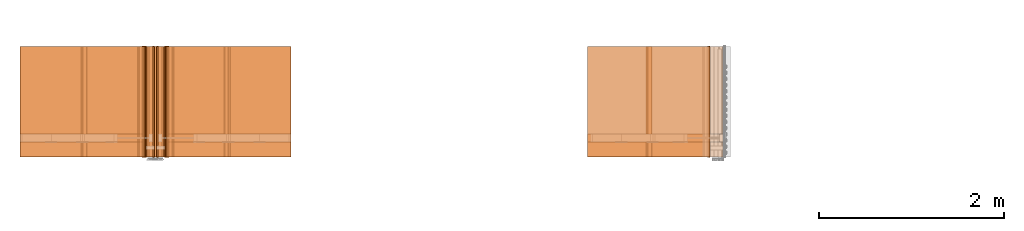
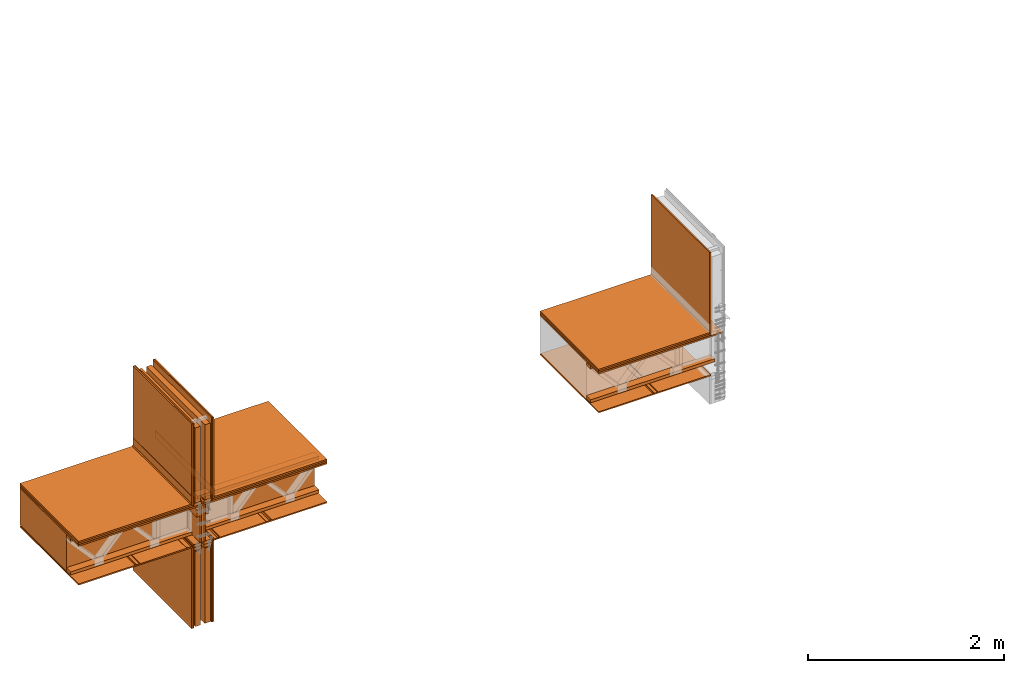
# One storey, part 1 of 22: 53 proxies.
"""IFC2X3 building model written with IfcOpenShell, lengths in feet."""

from ifc_helpers import new_model, entity, si_unit, converted_unit, frame, frame_2d, origin_with_axes, place, context, subcontext, project, spatial, polyline, rectangle, outline, extrude, element, save


model = new_model("IFC2X3")

# Units and contexts
model_context = context("Model", 3, precision=1e-05)
plan_context = context("Plan", 2, precision=1e-05, world=frame_2d((0.0, 0.0, 0.0), x_axis=(1.0, 0.0, 0.0)))
body_context_1 = subcontext(model_context, "Body", "Model", "MODEL_VIEW")
body_context_2 = subcontext(model_context, "Body", "Model", "MODEL_VIEW")
ifc_project = project(units=[converted_unit("VOLUMEUNIT", "cubic foot", entity("IfcReal", 0.0283168467116885), si_unit("VOLUMEUNIT", "CUBIC_METRE"), dimensions=[3, 0, 0, 0, 0, 0, 0]), converted_unit("AREAUNIT", "square foot", entity("IfcReal", 0.09290304), si_unit("AREAUNIT", "SQUARE_METRE"), dimensions=[2, 0, 0, 0, 0, 0, 0]), converted_unit("LENGTHUNIT", "foot", entity("IfcReal", 0.3048), si_unit("LENGTHUNIT", "METRE"), dimensions=[1, 0, 0, 0, 0, 0, 0])], contexts=[model_context, plan_context])

# Site, building, storey
site_placement = place(None, origin_with_axes())
site = spatial("IfcSite", under=ifc_project, at=site_placement, CompositionType="ELEMENT")
building_placement = place(site_placement, origin_with_axes())
building = spatial("IfcBuilding", under=site, at=building_placement, Name="Building", CompositionType="ELEMENT")
storey_placement = place(building_placement, origin_with_axes())
storey = spatial("IfcBuildingStorey", under=building, at=storey_placement, Name="Storey", CompositionType="ELEMENT")

# Proxies
proxy_1_placement = place(storey_placement, frame((1572.20384893142, 1.89104789667555, -60.1425383660424), z_axis=(0.0, 0.0, 1.0), x_axis=(1.0, 0.0, 0.0)))
element("IfcBuildingElementProxy", 1, at=proxy_1_placement, inside=storey, Name="Generic Models 841:Generic Models 1:245", context=body_context_1, shape_type="SweptSolid", body=[
    extrude(rectangle(XDim=9.6102735797045, YDim=3.92583333372057, at=frame_2d((0.0, 0.0, 0.0))), frame((3.63890071866393, 1.96291666644139, 0.0), z_axis=(0.0, 0.0, -1.0), x_axis=(-1.0, 0.0, 0.0)), (0.0, 0.0, -1.0), 0.0625000001175565),
])
proxy_2_placement = place(storey_placement, frame((1575.41560375784, 1.89104789667555, -65.0482227796019), z_axis=(0.0, 0.0, 1.0), x_axis=(-1.62920684942947e-07, 1.0, 0.0)))
element("IfcBuildingElementProxy", 2, at=proxy_2_placement, inside=storey, Name="Generic Models 845:Generic Models 1", context=body_context_1, shape_type="SweptSolid", body=[
    extrude(rectangle(XDim=3.92583333372057, YDim=0.0520833335148361, at=frame_2d((0.0, 0.0, 0.0))), frame((1.96291666644139, -0.0260416674977682, 0.0), z_axis=(0.0, 0.0, -1.0), x_axis=(-1.0, 0.0, 0.0)), (0.0, 0.0, -1.0), 3.31192968589252),
])
proxy_3_placement = place(storey_placement, frame((1572.20384893142, 1.89104789667555, -61.7362946037232), z_axis=(0.0, 0.0, 1.0), x_axis=(1.0, 0.0, 0.0)))
element("IfcBuildingElementProxy", 3, at=proxy_3_placement, inside=storey, Name="Generic Models 847:Generic Models 1:245", context=body_context_1, shape_type="SweptSolid", body=[
    extrude(rectangle(XDim=4.43001041812591, YDim=3.92583333372057, at=frame_2d((0.0, 0.0, 0.0))), frame((1.04876914675154, 1.96291666644139, 0.0), z_axis=(0.0, 0.0, -1.0), x_axis=(-0.999999940395355, 0.0, 0.0)), (0.0, 0.0, -1.0), 0.0520833335148361),
])
proxy_4_placement = place(storey_placement, frame((1572.20384893142, 1.89104789667555, -60.080036403626), z_axis=(0.0, 0.0, 1.0), x_axis=(1.0, 0.0, 0.0)))
element("IfcBuildingElementProxy", 4, at=proxy_4_placement, inside=storey, Name="Generic Models 849:Generic Models 1", context=body_context_1, shape_type="SweptSolid", body=[
    extrude(rectangle(XDim=4.43001041812591, YDim=3.92583333372057, at=frame_2d((0.0, 0.0, 0.0))), frame((1.04876914675154, 1.96291666644139, 0.0104166665407792), z_axis=(0.0, 0.0, -1.0), x_axis=(0.999999940395355, 0.0, 0.0)), (0.0, 0.0, -1.0), 0.0625000001175565),
])
proxy_5_placement = place(storey_placement, frame((1572.20384893142, 1.89104789667555, -60.017540698915), z_axis=(0.0, 0.0, 1.0), x_axis=(1.0, 0.0, 0.0)))
element("IfcBuildingElementProxy", 5, at=proxy_5_placement, inside=storey, Name="Generic Models 849:Generic Models 1", context=body_context_1, shape_type="SweptSolid", body=[
    extrude(rectangle(XDim=4.37794625465003, YDim=3.92583333372057, at=frame_2d((0.0, 0.0, 0.0))), frame((1.02273709192051, 1.96291666644139, 0.0104166665407792), z_axis=(0.0, 0.0, -1.0), x_axis=(1.0, 0.0, 0.0)), (0.0, 0.0, -1.0), 0.0625000001175565),
])
proxy_6_placement = place(storey_placement, frame((1572.20384893142, 1.89104789667555, -60.080036403626), z_axis=(0.0, 0.0, 1.0), x_axis=(1.0, 0.0, 0.0)))
element("IfcBuildingElementProxy", 6, at=proxy_6_placement, inside=storey, Name="Generic Models 849:Generic Models 1:245", context=body_context_1, shape_type="SweptSolid", body=[
    extrude(rectangle(XDim=4.43001041812591, YDim=3.92583333372057, at=frame_2d((0.0, 0.0, 0.0))), frame((1.04876914675154, 1.96291666644139, 0.0), z_axis=(0.0, 0.0, -1.0), x_axis=(-0.999999940395355, 0.0, 0.0)), (0.0, 0.0, -1.0), 0.0104166664774121),
])
proxy_7_placement = place(storey_placement, frame((1575.88438099138, 1.89104789667555, -61.8925432520589), z_axis=(0.0, 0.0, 1.0), x_axis=(-1.62920684942947e-07, 1.0, 0.0)))
element("IfcBuildingElementProxy", 7, at=proxy_7_placement, inside=storey, Name="Generic Models 857:Generic Models 1", context=body_context_1, shape_type="SweptSolid", body=[
    extrude(rectangle(XDim=0.291681873054029, YDim=3.92583333372057, at=frame_2d((0.0, 0.0, 0.0))), frame((1.96291666644139, -0.145840935233071, 0.125000001544871), z_axis=(0.0, 0.0, -1.0), x_axis=(0.0, 1.0, 0.0)), (0.0, 0.0, -1.0), 0.125000000235113),
])
proxy_8_placement = place(storey_placement, frame((1575.88438099138, 1.89104789667555, -60.080036403626), z_axis=(0.0, 0.0, 1.0), x_axis=(-1.62920684942947e-07, 1.0, 0.0)))
element("IfcBuildingElementProxy", 8, at=proxy_8_placement, inside=storey, Name="Generic Models 857:Generic Models 1", context=body_context_1, shape_type="SweptSolid", body=[
    extrude(rectangle(XDim=3.92583333372057, YDim=0.291681890238286, at=frame_2d((0.0, 0.0, 0.0))), frame((1.96291666644139, -0.145840947455152, 0.0), z_axis=(0.0, 0.0, -1.0), x_axis=(-1.0, 0.0, 0.0)), (0.0, 0.0, -1.0), 0.125000000235113),
])
proxy_9_placement = place(storey_placement, frame((1575.50931915523, 1.89104789667555, -60.080036403626), z_axis=(0.0, 0.0, 1.0), x_axis=(-1.62920684942947e-07, 1.0, 0.0)))
element("IfcBuildingElementProxy", 9, at=proxy_9_placement, inside=storey, Name="Generic Models 857:Generic Models 1", context=body_context_1, shape_type="SweptSolid", body=[
    extrude(rectangle(XDim=0.291681873054029, YDim=3.92583333372057, at=frame_2d((0.0, 0.0, 0.0))), frame((1.96291666644139, -0.145840935233071, 0.0), z_axis=(0.0, 0.0, -1.0), x_axis=(0.0, -1.0, 0.0)), (0.0, 0.0, -1.0), 0.125000000235113),
])
proxy_10_placement = place(storey_placement, frame((1575.46766786751, 0.875491228472842, -62.9761525652227), z_axis=(0.0, 0.0, 1.0), x_axis=(1.0, 0.0, 0.0)))
element("IfcBuildingElementProxy", 10, at=proxy_10_placement, inside=storey, Name="Plane", context=body_context_1, shape_type="SweptSolid", body=[
    extrude(rectangle(XDim=0.208333394207372, YDim=3.92583333372057, at=frame_2d((0.0, 0.0, 0.0))), frame((0.56250001306296, 2.97847343242075, -2.03039878465998), z_axis=(0.0, 0.0, -1.0), x_axis=(1.0, 0.0, 0.0)), (0.0, 0.0, -1.0), 3.07234290048816),
])
proxy_11_placement = place(storey_placement, frame((1575.46766786751, 0.875491228472842, -58.0079724469523), z_axis=(0.0, 0.0, 1.0), x_axis=(1.0, 0.0, 0.0)))
element("IfcBuildingElementProxy", 11, at=proxy_11_placement, inside=storey, Name="Plane", context=body_context_1, shape_type="SweptSolid", body=[
    extrude(rectangle(XDim=0.0416666640300221, YDim=3.92583333372057, at=frame_2d((0.0, 0.0, 0.0))), frame((0.0208333437758794, 2.97847343242075, -2.07206552110006), z_axis=(0.0, 0.0, -1.0), x_axis=(1.0, 0.0, 0.0)), (-5.38310507280926e-09, 0.0, -1.0), 3.40567790332094),
])
proxy_12_placement = place(storey_placement, frame((1575.46766786751, 0.875491228472842, -57.9246385829655), z_axis=(0.0, 0.0, 1.0), x_axis=(1.0, 0.0, 0.0)))
element("IfcBuildingElementProxy", 12, at=proxy_12_placement, inside=storey, Name="Plane", context=body_context_1, shape_type="SweptSolid", body=[
    extrude(rectangle(XDim=0.208333394207372, YDim=3.92583333372057, at=frame_2d((0.0, 0.0, 0.0))), frame((0.56250001306296, 2.97847343242075, -2.03039878465998), z_axis=(0.0, 0.0, -1.0), x_axis=(1.0, 0.0, 0.0)), (0.0, 0.0, -1.0), 3.07234290048816),
])
for number, where, z_axis, x_axis, name in (
    (13, (1575.46766786751, 0.875491228472842, -62.9761525652227), (0.0, 0.0, 1.0), (1.0, 0.0, 0.0), "Plane"),
    (14, (1575.46766786751, 0.875491228472842, -57.9246385829655), (0.0, 0.0, 1.0), (1.0, 0.0, 0.0), "Plane"),
):
    element("IfcBuildingElementProxy", number, at=place(storey_placement, frame(where, z_axis=z_axis, x_axis=x_axis)), inside=storey, Name=name, context=body_context_1, shape_type="SweptSolid", body=[
        extrude(rectangle(XDim=0.208333334059344, YDim=3.92583333372057, at=frame_2d((0.0, 0.0, 0.0))), frame((0.187500020650428, 2.97847343242075, -2.03039878465998), z_axis=(0.0, 0.0, -1.0), x_axis=(1.0, 0.0, 0.0)), (-7.95619570226336e-09, 0.0, -1.0), 3.07234290048816),
    ])
proxy_13_placement = place(storey_placement, frame((1576.2817703207, 1.89104809222885, -61.6842117209447), z_axis=(0.0, 0.0, 1.0), x_axis=(-1.62920684942947e-07, 1.0, 0.0)))
element("IfcBuildingElementProxy", 15, at=proxy_13_placement, inside=storey, Name="Dowel60:Dowel", context=body_context_1, shape_type="SweptSolid", body=[
    extrude(outline(polyline([(-0.0579994394299709, -0.0364231856251404), (-0.00643956394294115, -0.0364231856251404), (0.0797914282426121, 0.0498078065604128), (0.0797914282426121, 0.0792705903704867), (0.0745830984096827, 0.0792705903704867), (0.0745830922986422, 0.0519651658050814), (-0.00859693082641038, -0.0312148557922111), (-0.0601568017301597, -0.0312148527366908), (-0.0896195824847134, -0.0606776334912445), (-0.085936733362634, -0.0643604765022834), (-0.0579994394299709, -0.0364231856251404)])), frame((3.92583411509596, -0.112473822915022, 0.0212016179937664), z_axis=(1.0, 2.10234702535672e-05, 1.1531535164977e-05), x_axis=(-7.58548458179575e-06, 0.70710676908493, -0.70710676908493)), (5.46140836377162e-06, 2.08953169931192e-05, -1.0), 3.92583333463616),
])
proxy_14_placement = place(storey_placement, frame((1575.41560375784, 1.89104789667555, -60.080036403626), z_axis=(0.0, 0.0, 1.0), x_axis=(-1.62920684942947e-07, 1.0, 0.0)))
element("IfcBuildingElementProxy", 16, at=proxy_14_placement, inside=storey, Name="Generic Models 845:Generic Models 1", context=body_context_1, shape_type="SweptSolid", body=[
    extrude(rectangle(XDim=3.92583333372057, YDim=0.052083273366765, at=frame_2d((0.0, 0.0, 0.0))), frame((1.96291666644139, -0.82807121627287, 0.0729147843488558), z_axis=(0.0, 0.0, -1.0), x_axis=(-1.0, 0.0, 0.0)), (0.0, 0.0, -1.0), 3.33276164898647),
])
proxy_15_placement = place(storey_placement, frame((1575.41560375784, 1.89104789667555, -65.0482227796019), z_axis=(0.0, 0.0, 1.0), x_axis=(-1.62920684942947e-07, 1.0, 0.0)))
element("IfcBuildingElementProxy", 17, at=proxy_15_placement, inside=storey, Name="Generic Models 845:Generic Models 1", context=body_context_1, shape_type="SweptSolid", body=[
    extrude(rectangle(XDim=3.92583333372057, YDim=0.052083273366765, at=frame_2d((0.0, 0.0, 0.0))), frame((1.96291666644139, -0.82807121627287, 0.0), z_axis=(0.0, 0.0, -1.0), x_axis=(-1.0, 0.0, 0.0)), (0.0, 0.0, -1.0), 3.31192968589252),
])
proxy_16_placement = place(storey_placement, frame((1575.46766786751, 0.875491228472842, -62.9761588229282), z_axis=(0.0, 0.0, 1.0), x_axis=(1.0, 0.0, 0.0)))
element("IfcBuildingElementProxy", 18, at=proxy_16_placement, inside=storey, Name="Plane", context=body_context_1, shape_type="SweptSolid", body=[
    extrude(rectangle(XDim=3.92583333372057, YDim=0.0416667373353818, at=frame_2d((0.0, 0.0, 0.0))), frame((0.729220980421452, 2.97847343242075, -2.07206552110006), z_axis=(0.0, 0.0, -1.0), x_axis=(0.0, -1.0, 0.0)), (0.0, 1.4354937682981e-08, -1.0), 3.40567997555669),
])
proxy_17_placement = place(storey_placement, frame((1575.46766786751, 0.875491228472842, -58.0079724469523), z_axis=(0.0, 0.0, 1.0), x_axis=(1.0, 0.0, 0.0)))
element("IfcBuildingElementProxy", 19, at=proxy_17_placement, inside=storey, Name="Plane.003", context=body_context_1, shape_type="SweptSolid", body=[
    extrude(rectangle(XDim=3.92583333372057, YDim=0.0416667373353818, at=frame_2d((0.0, 0.0, 0.0))), frame((0.729220980421452, 2.97847343242075, -2.07206552110006), z_axis=(0.0, 0.0, -1.0), x_axis=(0.0, 1.0, 0.0)), (0.0, -1.43549465647652e-08, -1.0), 3.40567790332094),
])
proxy_18_placement = place(storey_placement, frame((1575.41560375784, 1.89104789667555, -60.080036403626), z_axis=(0.0, 0.0, 1.0), x_axis=(-1.62920684942947e-07, 1.0, 0.0)))
element("IfcBuildingElementProxy", 20, at=proxy_18_placement, inside=storey, Name="Generic Models 845:Generic Models 1", context=body_context_1, shape_type="SweptSolid", body=[
    extrude(rectangle(XDim=3.92583333372057, YDim=0.0520833335148361, at=frame_2d((0.0, 0.0, 0.0))), frame((1.96291666644139, -0.0260416674977682, 0.0729147843488558), z_axis=(0.0, 0.0, -1.0), x_axis=(-1.0, 0.0, 0.0)), (0.0, 0.0, -1.0), 3.33276164898647),
])
proxy_19_placement = place(storey_placement, frame((1575.46766786751, 0.875491228472842, -62.9761525652227), z_axis=(0.0, 0.0, 1.0), x_axis=(1.0, 0.0, 0.0)))
element("IfcBuildingElementProxy", 21, at=proxy_19_placement, inside=storey, Name="Plane", context=body_context_1, shape_type="SweptSolid", body=[
    extrude(rectangle(XDim=3.92583333372057, YDim=0.0416666640300221, at=frame_2d((0.0, 0.0, 0.0))), frame((0.0208333437758794, 2.97847343242075, -2.07206552110006), z_axis=(0.0, 0.0, -1.0), x_axis=(0.0, 1.0, 0.0)), (0.0, -5.83169690315799e-09, -1.0), 3.40567790332094),
])
proxy_20_placement = place(storey_placement, frame((1572.20384893142, 1.89104789667555, -60.017540698915), z_axis=(0.0, 0.0, 1.0), x_axis=(1.0, 0.0, 0.0)))
element("IfcBuildingElementProxy", 22, at=proxy_20_placement, inside=storey, Name="Generic Models 849:Generic Models 1", context=body_context_1, shape_type="SweptSolid", body=[
    extrude(rectangle(XDim=4.37815361509106, YDim=3.92583333372057, at=frame_2d((0.0, 0.0, 0.0))), frame((6.2549614843734, 1.96291666644139, 0.0104166665407792), z_axis=(0.0, 0.0, -1.0), x_axis=(-1.0, 0.0, 0.0)), (0.0, 0.0, -1.0), 0.0625000001175565),
])
proxy_21_placement = place(storey_placement, frame((1572.20384893142, 1.89104789667555, -60.080036403626), z_axis=(0.0, 0.0, 1.0), x_axis=(1.0, 0.0, 0.0)))
element("IfcBuildingElementProxy", 23, at=proxy_21_placement, inside=storey, Name="Generic Models 849:Generic Models 1", context=body_context_1, shape_type="SweptSolid", body=[
    extrude(rectangle(XDim=4.43031671374793, YDim=3.92583333372057, at=frame_2d((0.0, 0.0, 0.0))), frame((6.22887936789845, 1.96291666644139, 0.0104166665407792), z_axis=(0.0, 0.0, -1.0), x_axis=(1.0, 0.0, 0.0)), (0.0, 0.0, -1.0), 0.0625000001175565),
])
proxy_22_placement = place(storey_placement, frame((1572.20384893142, 1.89104789667555, -60.080036403626), z_axis=(0.0, 0.0, 1.0), x_axis=(1.0, 0.0, 0.0)))
element("IfcBuildingElementProxy", 24, at=proxy_22_placement, inside=storey, Name="Generic Models 849:Generic Models 1", context=body_context_1, shape_type="SweptSolid", body=[
    extrude(rectangle(XDim=4.43031787227273, YDim=3.92583333372057, at=frame_2d((0.0, 0.0, 0.0))), frame((6.22887936789845, 1.96291666644139, 0.0), z_axis=(0.0, 0.0, -1.0), x_axis=(-1.0, 0.0, 0.0)), (0.0, 0.0, -1.0), 0.0104166664774121),
])
for number, where, z_axis, x_axis, name in (
    (25, (1575.88438099138, 1.89104789667555, -62.0175471768917), (0.0, 0.0, 1.0), (-1.62920684942947e-07, 1.0, 0.0), "Generic Models 857:Generic Models 1"),
    (26, (1575.50931915523, 1.89104789667555, -62.0175471768917), (0.0, 0.0, 1.0), (-1.62920684942947e-07, 1.0, 0.0), "Generic Models 857:Generic Models 1"),
    (27, (1575.50931915523, 1.89104789667555, -61.8925432520589), (0.0, 0.0, 1.0), (-1.62920684942947e-07, 1.0, 0.0), "Generic Models 857:Generic Models 1"),
):
    element("IfcBuildingElementProxy", number, at=place(storey_placement, frame(where, z_axis=z_axis, x_axis=x_axis)), inside=storey, Name=name, context=body_context_1, shape_type="SweptSolid", body=[
        extrude(rectangle(XDim=0.291681873054029, YDim=3.92583333372057, at=frame_2d((0.0, 0.0, 0.0))), frame((1.96291666644139, -0.145840935233071, 0.125000001544871), z_axis=(0.0, 0.0, -1.0), x_axis=(0.0, -1.0, 0.0)), (0.0, 0.0, -1.0), 0.125000000235113),
    ])
proxy_23_placement = place(storey_placement, frame((1571.41567840977, 1.89104731001566, -61.6842117209447), z_axis=(0.0, 0.0, 1.0), x_axis=(-1.62920684942947e-07, 1.0, 0.0)))
element("IfcBuildingElementProxy", 28, at=proxy_23_placement, inside=storey, Name="Dowel60:Dowel", context=body_context_1, shape_type="SweptSolid", body=[
    extrude(outline(polyline([(0.0667669798132629, 0.015256727502982), (0.106276372286278, 0.015256727502982), (0.106276372286278, 0.0204650634469518), (0.064609629735155, 0.0204650573359113), (0.0281512659052851, -0.0159932851053168), (-0.0894830373954272, -0.0159932973273978), (-0.108790796572768, 0.00331454740450999), (-0.112473651805888, -0.000368289853557101), (-0.0916403813624945, -0.0212016363268879), (0.0303086098723524, -0.0212016149382461), (0.0667669798132629, 0.015256727502982)])), frame((3.92583372398937, -1.88752637291205, 0.0212016454934487), z_axis=(1.0, -1.85782892003772e-06, 0.0), x_axis=(0.0, 0.999999940395355, -7.73365513850877e-08)), (-4.17659351548139e-10, -4.49406556413123e-09, -1.0), 3.92583333372057),
])
proxy_24_placement = place(storey_placement, frame((1578.28173299474, 1.89104828778214, -61.6842117209447), z_axis=(0.0, 0.0, 1.0), x_axis=(-1.62920684942947e-07, 1.0, 0.0)))
element("IfcBuildingElementProxy", 29, at=proxy_24_placement, inside=storey, Name="Dowel60:Dowel", context=body_context_1, shape_type="SweptSolid", body=[
    extrude(outline(polyline([(-0.0601568078412002, 0.0312148619032516), (-0.00859693082641038, 0.0312148557922111), (0.0745830922986422, -0.0519651719161219), (0.0745830984096827, -0.0792705964815272), (0.0797914282426121, -0.0792705964815272), (0.0797914282426121, -0.049807809615933), (-0.00643956241518103, 0.036423191736181), (-0.0579994333189303, 0.0364231856251404), (-0.085936733362634, 0.0643604765022834), (-0.0896195763736729, 0.0606776334912445), (-0.0601568078412002, 0.0312148619032516)])), frame((7.80471796843667e-07, -0.112483185029092, 0.0211991903829215), z_axis=(-1.0, -2.10234720725566e-05, -1.15315469884081e-05), x_axis=(-6.7118080551154e-06, 0.70710676908493, -0.707106828689575)), (-5.45950661035022e-06, 2.0893143300782e-05, -1.0), 3.92583333463594),
])
proxy_25_placement = place(storey_placement, frame((1572.20384893142, 1.89104789667555, -61.7362946037232), z_axis=(0.0, 0.0, 1.0), x_axis=(1.0, 0.0, 0.0)))
element("IfcBuildingElementProxy", 30, at=proxy_25_placement, inside=storey, Name="Generic Models 847:Generic Models 1:245", context=body_context_1, shape_type="SweptSolid", body=[
    extrude(rectangle(XDim=4.43021606574954, YDim=3.92583333372057, at=frame_2d((0.0, 0.0, 0.0))), frame((6.22892942954236, 1.96291666644139, 0.0), z_axis=(0.0, 0.0, -1.0), x_axis=(-0.999999940395355, 0.0, 0.0)), (0.0, 0.0, -1.0), 0.0520833335148361),
])
proxy_26_placement = place(storey_placement, frame((1592.24552745268, 1.8910506344217, -61.7362820883123), z_axis=(0.0, 0.0, 1.0), x_axis=(1.0, 0.0, 0.0)))
element("IfcBuildingElementProxy", 31, at=proxy_26_placement, inside=storey, Name="Generic Models 847:Generic Models 1:245", context=body_context_1, shape_type="SweptSolid", body=[
    extrude(rectangle(XDim=4.34660765169413, YDim=3.92583333372057, at=frame_2d((0.0, 0.0, 0.0))), frame((1.09047049612511, 1.96291666644139, 0.0), z_axis=(0.0, 0.0, -1.0), x_axis=(1.0, 0.0, 0.0)), (0.0, 0.0, -1.0), 0.0520833335148361),
])
proxy_27_placement = place(storey_placement, frame((1595.45728227911, 1.8910506344217, -60.080036403626), z_axis=(0.0, 0.0, 1.0), x_axis=(-1.62920684942947e-07, 1.0, 0.0)))
element("IfcBuildingElementProxy", 32, at=proxy_27_placement, inside=storey, Name="Generic Models 845:Generic Models 1", context=body_context_1, shape_type="SweptSolid", body=[
    extrude(rectangle(XDim=3.92583333372057, YDim=0.0520833335148361, at=frame_2d((0.0, 0.0, 0.0))), frame((1.96291666644139, -0.0260416674977682, 0.0729147843488558), z_axis=(0.0, 0.0, -1.0), x_axis=(1.0, 0.0, 0.0)), (0.0, 0.0, -1.0), 3.33276164898647),
])
proxy_28_placement = place(storey_placement, frame((1592.24552745268, 1.8910506344217, -60.017540698915), z_axis=(0.0, 0.0, 1.0), x_axis=(1.0, 0.0, 0.0)))
element("IfcBuildingElementProxy", 33, at=proxy_28_placement, inside=storey, Name="Generic Models 849:Generic Models 1", context=body_context_1, shape_type="SweptSolid", body=[
    extrude(rectangle(XDim=4.29462533481383, YDim=3.92583333372057, at=frame_2d((0.0, 0.0, 0.0))), frame((1.06448830738468, 1.96291666644139, 0.0104166665407792), z_axis=(0.0, 0.0, -1.0), x_axis=(-1.0, 0.0, 0.0)), (0.0, 0.0, -1.0), 0.0625000001175565),
])
proxy_29_placement = place(storey_placement, frame((1592.24552745268, 1.8910506344217, -60.080036403626), z_axis=(0.0, 0.0, 1.0), x_axis=(1.0, 0.0, 0.0)))
element("IfcBuildingElementProxy", 34, at=proxy_29_placement, inside=storey, Name="Generic Models 849:Generic Models 1:245", context=body_context_1, shape_type="SweptSolid", body=[
    extrude(rectangle(XDim=4.34660765169413, YDim=3.92583333372057, at=frame_2d((0.0, 0.0, 0.0))), frame((1.09047049612511, 1.96291666644139, 0.0), z_axis=(0.0, 0.0, -1.0), x_axis=(-1.0, 0.0, 0.0)), (0.0, 0.0, -1.0), 0.0104166664774121),
])
proxy_30_placement = place(storey_placement, frame((1592.24552745268, 1.8910506344217, -60.080036403626), z_axis=(0.0, 0.0, 1.0), x_axis=(1.0, 0.0, 0.0)))
element("IfcBuildingElementProxy", 35, at=proxy_30_placement, inside=storey, Name="Generic Models 849:Generic Models 1", context=body_context_1, shape_type="SweptSolid", body=[
    extrude(rectangle(XDim=4.34660765169413, YDim=3.92583333372057, at=frame_2d((0.0, 0.0, 0.0))), frame((1.09047049612511, 1.96291666644139, 0.0104166665407792), z_axis=(0.0, 0.0, -1.0), x_axis=(1.0, 0.0, 0.0)), (0.0, 0.0, -1.0), 0.0625000001175565),
])
proxy_31_placement = place(storey_placement, frame((1592.20387616495, 1.89104789667555, -60.1425383660424), z_axis=(0.0, 0.0, 1.0), x_axis=(1.0, 0.0, 0.0)))
element("IfcBuildingElementProxy", 36, at=proxy_31_placement, inside=storey, Name="Generic Models 841:Generic Models 1:245", context=body_context_1, shape_type="SweptSolid", body=[
    extrude(rectangle(XDim=4.80505667753498, YDim=3.92583333372057, at=frame_2d((0.0, 0.0, 0.0))), frame((1.36134622916775, 1.96291666644139, 0.0), z_axis=(0.0, 0.0, -1.0), x_axis=(1.0, 0.0, 0.0)), (0.0, 0.0, -1.0), 0.0625000001175565),
])
proxy_32_placement = place(storey_placement, frame((1591.45735693103, 1.8910506344217, -61.6841992055337), z_axis=(0.0, 0.0, 1.0), x_axis=(-1.62920684942947e-07, 1.0, 0.0)))
element("IfcBuildingElementProxy", 37, at=proxy_32_placement, inside=storey, Name="Dowel60:Dowel", context=body_context_1, shape_type="SweptSolid", body=[
    extrude(outline(polyline([(-0.106276262287549, -0.0204650466415904), (-0.0646095319585068, -0.0204650466415904), (-0.0281511559065558, 0.0159932896885972), (0.0894831473941565, 0.0159932835775567), (0.108790906571497, -0.0033145642098714), (0.112473761804617, 0.000368273883689503), (0.0916404913612238, 0.0212016225770468), (-0.0303084998736231, 0.0212016195215265), (-0.0667668759255741, -0.0152567168086611), (-0.106276262287549, -0.0152567106976206), (-0.106276262287549, -0.0204650466415904)])), frame((3.92583411509596, -1.88752617735875, 0.0212016454934487), z_axis=(1.0, -1.44433724926785e-05, 5.75471631236724e-07), x_axis=(-9.38654284254881e-06, -1.0, -7.33323659574125e-08)), (7.52120149627444e-06, -5.71511520774948e-07, -1.0), 3.92583333383225),
])
proxy_33_placement = place(storey_placement, frame((1574.95723934624, 0.875493770665697, -59.9454707048071), z_axis=(0.0, 0.0, 1.0), x_axis=(1.0, 0.0, 0.0)))
element("IfcBuildingElementProxy", 38, at=proxy_33_placement, inside=storey, Name="Plane", context=body_context_1, shape_type="SweptSolid", body=[
    extrude(rectangle(XDim=4.70094978133192, YDim=3.10033562211458, at=frame_2d((0.0, 0.0, 0.0))), frame((-1.56912062894015, 3.39122229986616, -1.69706332871294), z_axis=(0.0, 0.0, -1.0), x_axis=(1.0, 0.0, 0.0)), (0.0, 0.0, -1.0), 1.49999431547957),
])
proxy_34_placement = place(storey_placement, frame((1573.4156410838, 1.89104770112225, -61.6842117209447), z_axis=(0.0, 0.0, 1.0), x_axis=(-1.62920684942947e-07, 1.0, 0.0)))
element("IfcBuildingElementProxy", 39, at=proxy_34_placement, inside=storey, Name="Dowel60:Dowel", context=body_context_1, shape_type="SweptSolid", body=[
    extrude(outline(polyline([(-0.106276262287549, -0.0204650466415904), (-0.0646095319585068, -0.0204650466415904), (-0.0281511559065558, 0.0159932896885972), (0.0894831473941565, 0.0159932835775567), (0.108790906571497, -0.0033145642098714), (0.112473761804617, 0.000368273883689503), (0.0916404913612238, 0.0212016225770468), (-0.0303084998736231, 0.0212016195215265), (-0.0667668759255741, -0.0152567168086611), (-0.106276262287549, -0.0152567106976206), (-0.106276262287549, -0.0204650466415904)])), frame((3.92583411509596, -1.88752617735875, 0.0212016454934487), z_axis=(1.0, -1.44433724926785e-05, 5.75471631236724e-07), x_axis=(-9.38654284254881e-06, -1.0, -7.33323659574125e-08)), (7.52120149627444e-06, -5.71511520774948e-07, -1.0), 3.92583333383225),
])
proxy_35_placement = place(storey_placement, frame((1571.84080188981, 2.42488121423196, -61.6425354023931), z_axis=(0.0, 0.0, 1.0), x_axis=(1.0, 0.0, 0.0)))
element("IfcBuildingElementProxy", 40, at=proxy_35_placement, inside=storey, Name="Generic Models 855:Generic Models 1", context=body_context_1, shape_type="SweptSolid", body=[
    extrude(rectangle(XDim=4.70100164291481, YDim=0.291666664589754, at=frame_2d((0.0, 0.0, 0.0))), frame((1.54728593006535, 0.145833528651966, 0.0), z_axis=(0.0, 0.0, -1.0), x_axis=(1.0, 0.0, 0.0)), (0.0, 0.0, -1.0), 0.125000000235113),
])
proxy_36_placement = place(storey_placement, frame((1571.84080188981, 2.42488121423196, -61.9758708583401), z_axis=(0.0, 0.0, 1.0), x_axis=(1.0, 0.0, 0.0)))
element("IfcBuildingElementProxy", 41, at=proxy_36_placement, inside=storey, Name="Generic Models 855:Generic Models 1", context=body_context_1, shape_type="SweptSolid", body=[
    extrude(rectangle(XDim=4.70100164291481, YDim=0.291666664589754, at=frame_2d((0.0, 0.0, 0.0))), frame((1.54728593006535, 0.145833528651966, 1.70833482517032), z_axis=(0.0, 0.0, -1.0), x_axis=(1.0, 0.0, 0.0)), (0.0, 0.0, -1.0), 0.125000015272121),
])
proxy_37_placement = place(storey_placement, frame((1575.68863996371, 2.57071606286867, -60.3839356129564), z_axis=(0.0, 0.0, 1.0), x_axis=(1.0, 0.0, 0.0)))
element("IfcBuildingElementProxy", 42, at=proxy_37_placement, inside=storey, Name="Generic Models 855:Generic Models 1", context=body_context_1, shape_type="SweptSolid", body=[
    extrude(rectangle(XDim=0.124999233345449, YDim=3.92583562166899, at=frame_2d((0.0, 0.0, 0.0))), frame((-0.0125009400325184, 1.28324986912134, -0.174600005228063), z_axis=(-1.56443593368749e-06, 0.0, -1.0), x_axis=(-0.999999940395355, 0.0, 1.56443593368749e-06)), (-1.12248699224438e-06, 0.0, -0.999999940395355), 0.291000029617698),
])
proxy_38_placement = place(storey_placement, frame((1575.78015264877, 1.8910506344217, -59.8092091678009), z_axis=(0.0, 0.0, 1.0), x_axis=(1.0, 0.0, 0.0)))
element("IfcBuildingElementProxy", 43, at=proxy_38_placement, inside=storey, Name="Generic Models 857:Generic Models 1", context=body_context_1, shape_type="SweptSolid", body=[
    extrude(rectangle(XDim=3.92583333372062, YDim=0.103999983757079, at=frame_2d((0.0, 0.0, 0.0))), frame((0.0624996646652071, 1.96291666644139, -1.83333014565816), z_axis=(0.0, 0.0, -1.0), x_axis=(1.61888735306093e-07, -1.0, 0.0)), (6.74533096045593e-09, -2.03701340240059e-08, -0.999999940395355), 1.49999998277201),
])
proxy_39_placement = place(storey_placement, frame((1575.09270615465, 1.89104789667555, -63.5482132278402), z_axis=(0.0, 0.0, 1.0), x_axis=(-1.62920684942947e-07, 1.0, 0.0)))
element("IfcBuildingElementProxy", 44, at=proxy_39_placement, inside=storey, Name="Generic Models 845:Generic Models 1", context=body_context_1, shape_type="SweptSolid", body=[
    extrude(rectangle(XDim=3.92583333372057, YDim=0.052083273366765, at=frame_2d((0.0, 0.0, 0.0))), frame((1.96291666644139, -0.82807121627287, 1.90567156774165), z_axis=(0.0, 0.0, -1.0), x_axis=(-1.0, 0.0, 0.0)), (0.0, 0.0, -1.0), 1.50000484807202),
])
proxy_40_placement = place(storey_placement, frame((1575.73860148432, 1.89104789667555, -63.5482132278402), z_axis=(0.0, 0.0, 1.0), x_axis=(-1.62920684942947e-07, 1.0, 0.0)))
element("IfcBuildingElementProxy", 45, at=proxy_40_placement, inside=storey, Name="Generic Models 845:Generic Models 1", context=body_context_1, shape_type="SweptSolid", body=[
    extrude(rectangle(XDim=3.92583333372057, YDim=0.0520833335148361, at=frame_2d((0.0, 0.0, 0.0))), frame((1.96291666644139, -0.0260416674977682, 1.90567156774165), z_axis=(0.0, 0.0, -1.0), x_axis=(-1.0, 0.0, 0.0)), (0.0, 0.0, -1.0), 1.50000484807202),
])
proxy_41_placement = place(storey_placement, frame((1576.72822006105, 0.875493770665697, -59.9454707048071), z_axis=(0.0, 0.0, 1.0), x_axis=(1.0, 0.0, 0.0)))
element("IfcBuildingElementProxy", 46, at=proxy_41_placement, inside=storey, Name="Plane", context=body_context_1, shape_type="SweptSolid", body=[
    extrude(rectangle(XDim=3.10033562211458, YDim=4.70094978133192, at=frame_2d((0.0, 0.0, 0.0))), frame((1.56912062894015, 3.39122229986616, -0.197069042330495), z_axis=(0.0, 0.0, -1.0), x_axis=(0.0, 1.0, 0.0)), (0.0, 0.0, 1.0), 1.49999431547957),
])
proxy_42_placement = place(storey_placement, frame((1575.99681944359, 2.57071606286867, -60.3839356129564), z_axis=(0.0, 0.0, 1.0), x_axis=(1.0, 0.0, 0.0)))
element("IfcBuildingElementProxy", 47, at=proxy_42_placement, inside=storey, Name="Generic Models 855:Generic Models 1", context=body_context_1, shape_type="SweptSolid", body=[
    extrude(rectangle(XDim=3.92583562166899, YDim=0.124999233345449, at=frame_2d((0.0, 0.0, 0.0))), frame((0.0125001578193324, 1.28324977134469, 0.116400019781483), z_axis=(1.56443593368749e-06, 0.0, -1.0), x_axis=(0.0, -1.0, 0.0)), (0.0, -1.12460190848651e-06, 0.999999940395355), 0.291000029617699),
])
proxy_43_placement = place(storey_placement, frame((1575.94685792297, 1.89104809222885, -61.6425416600986), z_axis=(0.0, 0.0, 1.0), x_axis=(1.0, 0.0, 0.0)))
element("IfcBuildingElementProxy", 48, at=proxy_43_placement, inside=storey, Name="Generic Models 855:Generic Models 1", context=body_context_1, shape_type="SweptSolid", body=[
    extrude(rectangle(XDim=0.291666613034289, YDim=4.70100164291481, at=frame_2d((0.0, 0.0, 0.0))), frame((2.35049430466699, 0.679666601766751, 0.125008227005405), z_axis=(0.0, 0.0, -1.0), x_axis=(0.0, -1.0, 0.0)), (0.0, 0.0, 1.0), 0.125000015272121),
])
proxy_44_placement = place(storey_placement, frame((1575.94685792297, 2.42488140978525, -60.1425383660424), z_axis=(0.0, 0.0, 1.0), x_axis=(1.0, 0.0, 0.0)))
element("IfcBuildingElementProxy", 49, at=proxy_44_placement, inside=storey, Name="Generic Models 855:Generic Models 1", context=body_context_1, shape_type="SweptSolid", body=[
    extrude(rectangle(XDim=0.291666664589754, YDim=4.70100164291481, at=frame_2d((0.0, 0.0, 0.0))), frame((2.35051346889005, 0.145833333098669, 2.34663955808625e-06), z_axis=(0.0, 0.0, -1.0), x_axis=(0.0, -1.0, 0.0)), (0.0, 0.0, 1.0), 0.125000015272121),
])
proxy_45_placement = place(storey_placement, frame((1591.96588310983, 2.42488121423196, -61.9758708583401), z_axis=(0.0, 0.0, 1.0), x_axis=(1.0, 0.0, 0.0)))
element("IfcBuildingElementProxy", 50, at=proxy_45_placement, inside=storey, Name="Generic Models 855:Generic Models 1", context=body_context_1, shape_type="SweptSolid", body=[
    extrude(rectangle(XDim=4.68007571020062, YDim=0.291666664589754, at=frame_2d((0.0, 0.0, 0.0))), frame((1.53682304648902, 0.145833528651966, 1.70833482517032), z_axis=(0.0, 0.0, -1.0), x_axis=(-1.0, 0.0, 0.0)), (0.0, 0.0, -1.0), 0.125000015272121),
])
proxy_46_placement = place(storey_placement, frame((1591.96588310983, 2.42488121423196, -61.6425354023931), z_axis=(0.0, 0.0, 1.0), x_axis=(1.0, 0.0, 0.0)))
element("IfcBuildingElementProxy", 51, at=proxy_46_placement, inside=storey, Name="Generic Models 855:Generic Models 1", context=body_context_1, shape_type="SweptSolid", body=[
    extrude(rectangle(XDim=4.80502970608762, YDim=0.291666664589754, at=frame_2d((0.0, 0.0, 0.0))), frame((1.59929997808351, 0.145833528651966, 0.0), z_axis=(0.0, 0.0, -1.0), x_axis=(-1.0, 0.0, 0.0)), (0.0, 0.0, -1.0), 0.125000000235113),
])
proxy_47_placement = place(storey_placement, frame((1575.41560375784, 1.93269840219202, -60.0175156680931), z_axis=(0.0, 0.0, 1.0), x_axis=(1.0, 0.0, 0.0)))
element("IfcBuildingElementProxy", 52, at=proxy_47_placement, inside=storey, Name="Vert", context=body_context_2, shape_type="SweptSolid", body=[
    extrude(outline(polyline([(0.0544250123887237, 0.0639969673682386), (0.103143290702126, 0.0639969673682386), (0.103143290702126, 0.0744464433216673), (0.0500967029452793, 0.0744464494327078), (-0.159098605412667, -0.134748944479806), (-0.15170970965871, -0.142137840233763), (0.0544250123887237, 0.0639969673682386)])), frame((-0.0171809383298899, -0.0416501907978862, 0.198470609472805), z_axis=(-6.57969323469842e-09, -1.0, 2.08816845770343e-06), x_axis=(-0.707106828689575, -1.44251725942013e-06, -0.707106649875641)), (3.28998268628311e-08, -1.4804788861511e-06, -1.0), 3.92583022864989),
])
proxy_48_placement = place(storey_placement, frame((1576.26975552616, 5.77522779074241, -60.0175156680931), z_axis=(0.0, 0.0, 1.0), x_axis=(-1.0, -3.25841369885893e-07, 0.0)))
element("IfcBuildingElementProxy", 53, at=proxy_48_placement, inside=storey, Name="Vert", context=body_context_2, shape_type="SweptSolid", body=[
    extrude(outline(polyline([(0.207891805082794, -7.65745006044874e-10), (0.208232018930393, 0.0104439370590812), (-0.0874580524548927, 0.0200758787761797), (-0.126168982485148, -0.0161926471078255), (-0.119024552795987, -0.0238181837391978), (-0.0834722423881996, 0.0094910249422033), (0.207891805082794, -7.65745006044874e-10)])), frame((-0.0171850373103159, 3.88417969851356, 0.198466502853579), z_axis=(-8.71472252583771e-07, 1.0, -2.78422498922737e-06), x_axis=(0.0325571373105049, 1.88129877187748e-06, 0.999469816684723)), (-8.03013961103716e-07, 2.29300667342613e-07, -1.0), 3.92582973837173),
])

save(model, "model.ifc")
